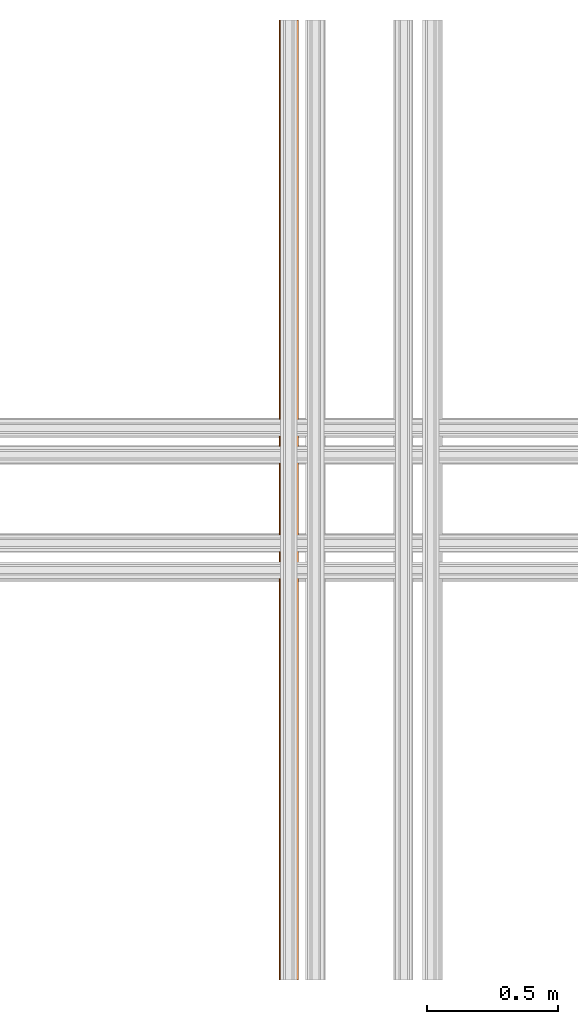
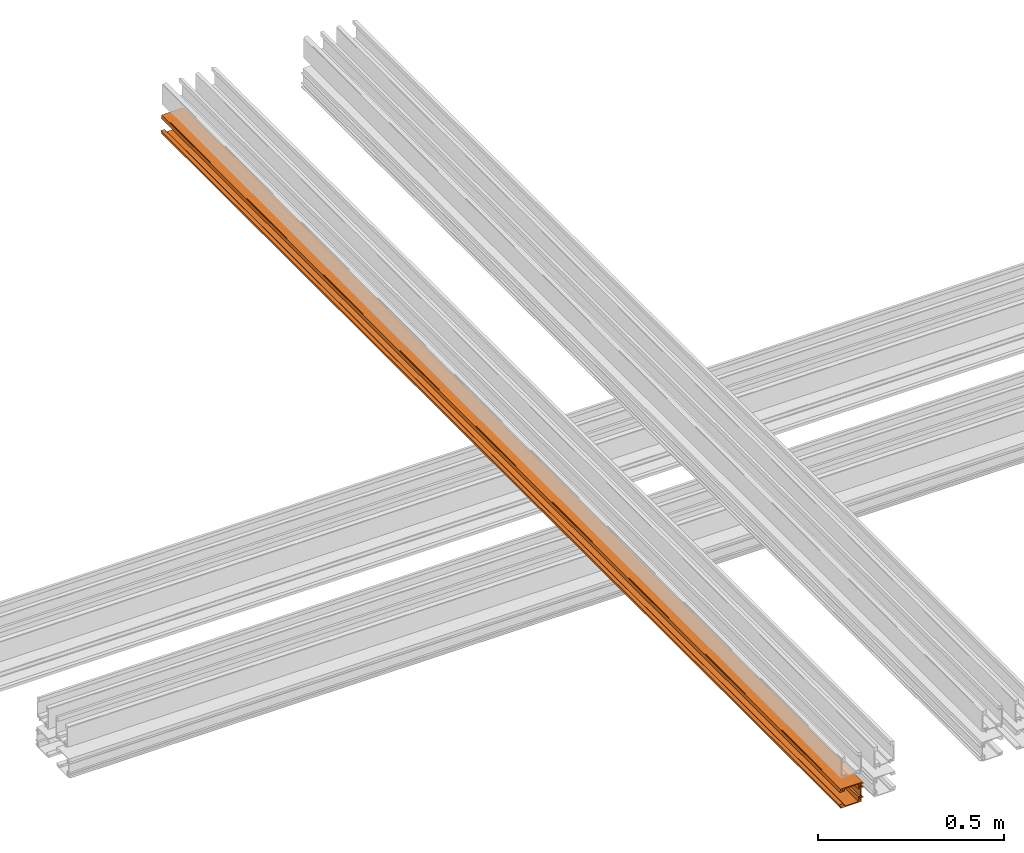
# One storey, part 4 of 4: 1 proxy.
"""IFC2X3 building model written with IfcOpenShell, lengths in feet."""

import ifcopenshell
import ifcopenshell.guid

model = None  # the IFC model being written
_history = None  # IfcOwnerHistory: only IFC2X3 demands one
_inside = {}  # id of a spatial element -> (the spatial element, [elements in it])
_under = {}  # id of a project, library or spatial element -> (it, [spatial elements below it])
_declared = {}  # id of a project -> (the project, [libraries it declares])
_typed = {}  # id of a type object -> (the type object, [elements of that type])
_made_of = {}  # id of a material, layer set ... -> (it, [elements and type objects made of it])


def new_model(schema):
    """Start an empty IFC model of exactly this schema.

    Asked for "IFC4X3", IfcOpenShell would pick the latest addendum, in which some entities
    have other attributes; the version numbers below select the first issue.
    IFC2X3 requires an IfcOwnerHistory on every rooted entity: one is made here for all.
    """
    global model, _history
    if schema == "IFC4X3":
        model = ifcopenshell.file(schema_version=(4, 3, 0, 0))
    else:
        model = ifcopenshell.file(schema=schema)
    _inside.clear()
    _under.clear()
    _declared.clear()
    _typed.clear()
    _made_of.clear()
    _history = None
    if model.schema == "IFC2X3":
        org = make("IfcOrganization", Name="unknown")
        user = make(
            "IfcPersonAndOrganization",
            ThePerson=make("IfcPerson", FamilyName="unknown"),
            TheOrganization=org,
        )
        app = make(
            "IfcApplication",
            ApplicationDeveloper=org,
            Version="unknown",
            ApplicationFullName="unknown",
            ApplicationIdentifier="unknown",
        )
        _history = make(
            "IfcOwnerHistory",
            OwningUser=user,
            OwningApplication=app,
            ChangeAction="ADDED",
            CreationDate=0,
        )
    return model


def make(cls, **values):
    """One entity of the class cls with the attributes given. An attribute that is None is left unset."""
    return model.create_entity(
        cls, **{name: value for name, value in values.items() if value is not None}
    )


def entity(cls, *values):
    """Any entity or typed value of the class cls, its attributes in the order of the schema. None: left unset."""
    e = model.create_entity(cls)
    for i, value in enumerate(values):
        if value is not None:
            e[i] = value
    return e


def rooted(cls, **values):
    """An entity with a GlobalId (a new one), such as an element, a storey or a relation."""
    return make(cls, GlobalId=ifcopenshell.guid.new(), OwnerHistory=_history, **values)


def si_unit(unit_type, name, prefix=None):
    """IfcSIUnit, for example si_unit("LENGTHUNIT", "METRE", prefix="MILLI")."""
    return make("IfcSIUnit", UnitType=unit_type, Prefix=prefix, Name=name)


def converted_unit(unit_type, name, factor, base, dimensions=None, offset=None):
    """IfcConversionBasedUnit, such as the inch: factor (a typed value) times the base unit."""
    return make(
        "IfcConversionBasedUnit"
        if offset is None
        else "IfcConversionBasedUnitWithOffset",
        ConversionOffset=offset,
        Dimensions=None
        if dimensions is None
        else entity("IfcDimensionalExponents", *dimensions),
        UnitType=unit_type,
        Name=name,
        ConversionFactor=make(
            "IfcMeasureWithUnit", ValueComponent=factor, UnitComponent=base
        ),
    )


def derived_unit(unit_type, elements):
    """IfcDerivedUnit: a product of units, each with its exponent."""
    return make(
        "IfcDerivedUnit",
        Elements=[
            make("IfcDerivedUnitElement", Unit=unit, Exponent=power)
            for unit, power in elements
        ],
        UnitType=unit_type,
    )


def assignment(units):
    """IfcUnitAssignment: the units of a project."""
    return None if units is None else make("IfcUnitAssignment", Units=units)


def point(xyz):
    """IfcCartesianPoint."""
    return None if xyz is None else make("IfcCartesianPoint", Coordinates=xyz)


def direction(xyz):
    """IfcDirection."""
    return None if xyz is None else make("IfcDirection", DirectionRatios=xyz)


def frame(location, z_axis=None, x_axis=None):
    """IfcAxis2Placement3D, a coordinate frame: its origin and axes. An axis left out is left unset."""
    return make(
        "IfcAxis2Placement3D",
        Location=point(location),
        Axis=direction(z_axis),
        RefDirection=direction(x_axis),
    )


def origin():
    """The frame at (0, 0, 0) with its axes left unset."""
    return frame((0.0, 0.0, 0.0))


def place(relative_to, where):
    """IfcLocalPlacement: puts the frame where relative to a parent placement (None: the world)."""
    return make(
        "IfcLocalPlacement", PlacementRelTo=relative_to, RelativePlacement=where
    )


def context(
    kind, dimensions, precision=None, world=None, true_north=None, identifier=None
):
    """IfcGeometricRepresentationContext, for example the 3D "Model" context."""
    return make(
        "IfcGeometricRepresentationContext",
        ContextIdentifier=identifier,
        ContextType=kind,
        CoordinateSpaceDimension=dimensions,
        Precision=precision,
        WorldCoordinateSystem=world,
        TrueNorth=true_north,
    )


def subcontext(parent, identifier, kind, view, scale=None):
    """IfcGeometricRepresentationSubContext, for example "Body" below "Model"."""
    return make(
        "IfcGeometricRepresentationSubContext",
        ContextIdentifier=identifier,
        ContextType=kind,
        ParentContext=parent,
        TargetScale=scale,
        TargetView=view,
    )


def project(units=None, contexts=None):
    """IfcProject with its units and contexts."""
    return rooted(
        "IfcProject",
        Name="project",
        RepresentationContexts=contexts,
        UnitsInContext=assignment(units),
    )


def spatial(cls, under=None, at=None, **own):
    """A site, building, storey or space (cls), placed at a placement, below another one or the project."""
    s = rooted(cls, ObjectPlacement=at, **own)
    if under is not None:
        _under.setdefault(under.id(), (under, []))[1].append(s)
    return s


def polyline(points):
    """IfcPolyline through the points."""
    return make("IfcPolyline", Points=[point(p) for p in points])


def outline(outer, holes=None, kind="AREA"):
    """IfcArbitraryClosedProfileDef: a profile drawn as a closed curve; with holes, ...WithVoids."""
    if holes is None:
        return make("IfcArbitraryClosedProfileDef", ProfileType=kind, OuterCurve=outer)
    return make(
        "IfcArbitraryProfileDefWithVoids",
        ProfileType=kind,
        OuterCurve=outer,
        InnerCurves=holes,
    )


def extrude(swept, where, along, depth):
    """IfcExtrudedAreaSolid: the profile swept, set in the frame where, extruded along a direction by depth."""
    return make(
        "IfcExtrudedAreaSolid",
        SweptArea=swept,
        Position=where,
        ExtrudedDirection=direction(along),
        Depth=depth,
    )


def shape(context_of_items, identifier, shape_type, items):
    """IfcShapeRepresentation: the items that make up one representation, for example the "Body"."""
    return make(
        "IfcShapeRepresentation",
        ContextOfItems=context_of_items,
        RepresentationIdentifier=identifier,
        RepresentationType=shape_type,
        Items=items,
    )


def source(mapping_origin, context_of_items, identifier, shape_type, items):
    """IfcRepresentationMap: a shape defined once, which mapped items show again and again."""
    return make(
        "IfcRepresentationMap",
        MappingOrigin=mapping_origin,
        MappedRepresentation=shape(context_of_items, identifier, shape_type, items),
    )


def transform(
    local_origin,
    x_axis=None,
    y_axis=None,
    z_axis=None,
    scale=None,
    scale2=None,
    scale3=None,
    uniform=True,
):
    """IfcCartesianTransformationOperator3D, or its non-uniform kind. x_axis, y_axis, z_axis: its Axis1, 2, 3."""
    if uniform:
        return make(
            "IfcCartesianTransformationOperator3D",
            Axis1=direction(x_axis),
            Axis2=direction(y_axis),
            LocalOrigin=point(local_origin),
            Scale=scale,
            Axis3=direction(z_axis),
        )
    return make(
        "IfcCartesianTransformationOperator3DnonUniform",
        Axis1=direction(x_axis),
        Axis2=direction(y_axis),
        LocalOrigin=point(local_origin),
        Scale=scale,
        Axis3=direction(z_axis),
        Scale2=scale2,
        Scale3=scale3,
    )


def mapped(mapping_source, mapping_target):
    """IfcMappedItem: shows the shape of a source again, moved by a transform."""
    return make(
        "IfcMappedItem", MappingSource=mapping_source, MappingTarget=mapping_target
    )


def material(Name=None, Category=None):
    """IfcMaterial."""
    return make("IfcMaterial", Name=Name, Category=Category)


def made_of(thing, what):
    """Note that an element or type object is made of a material, layer set ...; save() writes the relation."""
    if what is not None:
        _made_of.setdefault(what.id(), (what, []))[1].append(thing)
    return thing


def type_object(cls, material=None, **own):
    """A type object (cls), such as IfcWallType, which elements share."""
    return made_of(rooted(cls, **own), material)


def type_shapes(of_type, sources):
    """Give a type object the sources (RepresentationMaps) that its elements show as mapped items."""
    of_type.RepresentationMaps = sources


def element(
    cls,
    number,
    at=None,
    inside=None,
    cuts=None,
    type_object=None,
    material=None,
    context=None,
    identifier="Body",
    shape_type=None,
    held_by="IfcProductDefinitionShape",
    body=None,
    shapes=None,
    **own,
):
    """One element of the class cls, such as IfcWall. Its Tag is "e" and its number.

    at: its placement. inside: the storey or other place that contains it. cuts: it is an
    opening in that element (IfcRelVoidsElement). A single representation is given by context,
    identifier, shape_type and body (its items); several are given by shapes. held_by: the class
    of the entity that holds the representations. save() writes the other relations.
    """
    e = rooted(cls, Tag="e%d" % number, ObjectPlacement=at, **own)
    if body is not None:
        shapes = [shape(context, identifier, shape_type, body)]
    if shapes is not None:
        e.Representation = make(held_by, Representations=shapes)
    if inside is not None:
        _inside.setdefault(inside.id(), (inside, []))[1].append(e)
    if cuts is not None:
        rooted(
            "IfcRelVoidsElement", RelatingBuildingElement=cuts, RelatedOpeningElement=e
        )
    if type_object is not None:
        _typed.setdefault(type_object.id(), (type_object, []))[1].append(e)
    return made_of(e, material)


def aggregate(whole, parts):
    """IfcRelAggregates: a whole, such as a stair, and the parts it consists of."""
    return rooted("IfcRelAggregates", RelatingObject=whole, RelatedObjects=parts)


def save(model, path):
    """Write the relations noted so far, then the file.

    IfcRelAggregates (storeys below a building ...), IfcRelContainedInSpatialStructure (elements
    in a storey), IfcRelDefinesByType, IfcRelAssociatesMaterial and IfcRelDeclares: one each for
    every whole, place, type object, material and project.
    """
    for whole, parts in _under.values():
        aggregate(whole, parts)
    for where, things in _inside.values():
        rooted(
            "IfcRelContainedInSpatialStructure",
            RelatedElements=things,
            RelatingStructure=where,
        )
    for kind, things in _typed.values():
        rooted("IfcRelDefinesByType", RelatedObjects=things, RelatingType=kind)
    for what, things in _made_of.values():
        rooted("IfcRelAssociatesMaterial", RelatedObjects=things, RelatingMaterial=what)
    for by, libraries in _declared.values():
        rooted("IfcRelDeclares", RelatingContext=by, RelatedDefinitions=libraries)
    model.write(path)


model = new_model("IFC2X3")

# Units and contexts
model_context = context("Model", 3, precision=0.0001, world=origin(), true_north=direction((6.12303176911189e-17, 1.0)))
body_context = subcontext(model_context, "Body", "Model", "MODEL_VIEW")
ifc_project = project(units=[converted_unit("LENGTHUNIT", "FOOT", entity("IfcRatioMeasure", 0.3048), si_unit("LENGTHUNIT", "METRE"), dimensions=[1, 0, 0, 0, 0, 0, 0]), converted_unit("AREAUNIT", "SQUARE FOOT", entity("IfcRatioMeasure", 0.09290304), si_unit("AREAUNIT", "SQUARE_METRE"), dimensions=[2, 0, 0, 0, 0, 0, 0]), converted_unit("VOLUMEUNIT", "CUBIC FOOT", entity("IfcRatioMeasure", 0.028316846592), si_unit("VOLUMEUNIT", "CUBIC_METRE"), dimensions=[3, 0, 0, 0, 0, 0, 0]), converted_unit("PLANEANGLEUNIT", "DEGREE", entity("IfcRatioMeasure", 0.0174532925199433), si_unit("PLANEANGLEUNIT", "RADIAN"), dimensions=[0, 0, 0, 0, 0, 0, 0]), si_unit("MASSUNIT", "GRAM", prefix="KILO"), derived_unit("MASSDENSITYUNIT", [(si_unit("MASSUNIT", "GRAM", prefix="KILO"), 1), (si_unit("LENGTHUNIT", "METRE"), -3)]), si_unit("TIMEUNIT", "SECOND"), si_unit("FREQUENCYUNIT", "HERTZ"), si_unit("THERMODYNAMICTEMPERATUREUNIT", "DEGREE_CELSIUS"), derived_unit("THERMALTRANSMITTANCEUNIT", [(si_unit("MASSUNIT", "GRAM", prefix="KILO"), 1), (si_unit("THERMODYNAMICTEMPERATUREUNIT", "KELVIN"), -1), (si_unit("TIMEUNIT", "SECOND"), -3)]), derived_unit("VOLUMETRICFLOWRATEUNIT", [(si_unit("LENGTHUNIT", "METRE"), 3), (si_unit("TIMEUNIT", "SECOND"), -1)]), si_unit("ELECTRICCURRENTUNIT", "AMPERE"), si_unit("ELECTRICVOLTAGEUNIT", "VOLT"), si_unit("POWERUNIT", "WATT"), si_unit("FORCEUNIT", "NEWTON"), si_unit("ILLUMINANCEUNIT", "LUX"), si_unit("LUMINOUSFLUXUNIT", "LUMEN"), si_unit("LUMINOUSINTENSITYUNIT", "CANDELA"), derived_unit("USERDEFINED", [(si_unit("MASSUNIT", "GRAM", prefix="KILO"), -1), (si_unit("LENGTHUNIT", "METRE"), -2), (si_unit("TIMEUNIT", "SECOND"), 3), (si_unit("LUMINOUSFLUXUNIT", "LUMEN"), 1)]), derived_unit("LINEARVELOCITYUNIT", [(si_unit("LENGTHUNIT", "METRE"), 1), (si_unit("TIMEUNIT", "SECOND"), -1)]), si_unit("PRESSUREUNIT", "PASCAL"), derived_unit("USERDEFINED", [(si_unit("LENGTHUNIT", "METRE"), -2), (si_unit("MASSUNIT", "GRAM", prefix="KILO"), 1), (si_unit("TIMEUNIT", "SECOND"), -2)])], contexts=[model_context])

# Site, building, storey
site_placement = place(None, origin())
site = spatial("IfcSite", under=ifc_project, at=site_placement, CompositionType="ELEMENT")
building_placement = place(site_placement, origin())
building = spatial("IfcBuilding", under=site, at=building_placement, CompositionType="ELEMENT")
storey_placement = place(building_placement, origin())
storey = spatial("IfcBuildingStorey", under=building, at=storey_placement, Name="Level 1", CompositionType="ELEMENT", Elevation=0.0)

# Proxy
ifc_material = material(Name="THERMAL BROKEN ALUMINUM STOREFRONT FOR POLYCARBONATE")
building_element_proxy_type = type_object("IfcBuildingElementProxyType", Name="Generic Models 2", PredefinedType="NOTDEFINED", material=ifc_material)
shared_shape = source(origin(), body_context, "Body", "SweptSolid", [
    extrude(outline(polyline([(-0.0104080468283571, -0.0212270141141865), (0.0284072982254619, -0.0212270141141865), (0.0185964943745741, 0.0155635003266429), (-0.00515653981588791, 0.0270511459549447), (-0.00897742822638776, 0.0260322423788114), (-0.00514872339515044, 0.0116745992616716), (-0.0064740101252062, -0.00299045881680828), (-0.00136839731267846, -0.00250162354759874), (0.00181539143775597, -0.0144408313617281), (-0.0112860383341235, -0.0179345459675626), (-0.0104080468283571, -0.0212270141141865)])), frame((-15.0474625405981, 0.579193333610883, -0.488678668263244), z_axis=(1.0, 0.0, 0.0), x_axis=(0.0, 0.257662650560332, 0.966234939601246)), (0.0, 0.0, 1.0), 12.0),
    extrude(outline(polyline([(0.0679666623619383, 0.000632417738883341), (0.0710872151823902, 0.000632417738883342), (0.072579012039196, 0.00314266314992776), (0.0702488184526765, 0.00635088523716542), (0.0700096732994305, 0.0109637083615181), (0.0775858665392125, 0.0113564851588299), (0.0770520929428696, 0.0216523375102529), (-0.134304272308872, 0.0106948719853311), (-0.133377721915217, -0.00717717360587389), (-0.123081869563794, -0.00664340000953091), (-0.122412698736183, -0.000765203056202739), (-0.106181130798194, -0.00576720561553113), (-0.0921943125095252, -0.00504207922050203), (-0.092587089306837, 0.00253411401928001), (0.0533031958989612, 0.0100975851674497), (0.0553677918848116, -0.0297259946823082), (0.0598635549062836, -0.029492918341043), (0.0628161856570253, 0.00318899968962246), (0.0662590259738255, 0.00336748877384854), (0.0679666623619383, 0.000632417738883341)])), frame((-15.0474625405981, 0.459395210905167, -0.491860847636116), z_axis=(1.0, 0.0, 0.0), x_axis=(0.0, -0.99865882581399, 0.05177402460523)), (0.0, 0.0, 1.0), 12.0),
    extrude(outline(polyline([(-0.0730229494703184, 0.10703462932325), (-0.0580447359626436, 0.10703462932325), (-0.0580447359626436, 0.113745897781071), (-0.0623242255363625, 0.118025006955696), (-0.0623242255363624, 0.112092207910207), (-0.0671872818698961, 0.112092207910207), (-0.070447847400705, 0.11773967307098), (-0.070447847400705, 0.125224643652343), (-0.067542920423974, 0.131454279657517), (-0.0623242255363624, 0.131454279657517), (-0.0623242255363624, 0.124783598829804), (-0.0580447359626436, 0.125514243391176), (-0.0580447359626435, 0.142048634925557), (-0.0813874063643329, 0.140085232742292), (-0.0813874063643329, -0.0647285203812247), (-0.0697160711634882, -0.0647285203812247), (-0.0697160711634882, -0.0853478792356713), (-0.0631023145498278, -0.0853478792356712), (-0.0631023145498279, -0.0647285203809973), (-0.027310219934056, -0.0647285203809974), (-0.0273102199340559, -0.0853478792356713), (-0.0206964633203955, -0.0853478792356713), (-0.0206964633203956, -0.0647285203809974), (0.0812331974328895, -0.0647285203809974), (0.0812331974328896, -0.0853478792356713), (0.08784695404655, -0.0853478792356713), (0.0878469540465499, -0.0647285203812247), (0.116052680781773, -0.0647285203812247), (0.116052680781773, -0.0602545085540827), (0.113329369234955, -0.0585038082739666), (0.110217013181205, -0.0606435530609291), (0.0878469540467773, -0.0606435530609291), (0.0835674644730585, -0.0563640634872103), (0.0713125625121716, -0.0563640634872103), (0.0713125625121717, -0.0388570606861707), (0.115469114021731, -0.0388570606861707), (0.115469114021731, -0.0337994820992139), (0.0646988058985113, -0.0337994820992139), (0.0646988058985112, -0.0563640634872103), (-0.0203074188135492, -0.0563640634872103), (-0.0203074188135491, -0.0337994820992139), (-0.0730229494703184, -0.0337994820992138), (-0.0730229494703184, 0.10703462932325)]), holes=[polyline([(-0.0710777269369959, -0.057725719260718), (-0.0710777269369958, -0.0388570606861707), (-0.0273102199340559, -0.0388570606861707), (-0.027310219934056, -0.057725719260718), (-0.0710777269369959, -0.057725719260718)])]), frame((-15.0474625405981, 0.4470265612332, -0.382548921665172), z_axis=(1.0, 0.0, 0.0), x_axis=(0.0, 0.0, -1.0)), (0.0, 0.0, 1.0), 12.0),
    extrude(outline(polyline([(-0.0218274236802372, -0.025076209688489), (0.0116463755794956, -0.025076209688489), (0.0131456738465899, -0.0183468011873072), (-0.00944342914962783, -0.0152716423802922), (-0.00556193395869956, 0.00214995231397101), (0.000832544625431189, 0.00182921635388828), (-0.000621696809064723, -0.00469796031725753), (0.00265859892029526, -0.0054288034072145), (0.00663400184610042, -0.000259219921661603), (0.00811823413249314, 0.00640256685218482), (0.00642611525779212, 0.0117890219260673), (0.00293818751194467, 0.012566124998972), (0.00132974729935316, 0.00534684683544), (-0.00324578604653784, 0.0125456859662898), (-0.00165600184121952, 0.0196812290274093), (-0.011373207534109, 0.0218462023164866), (-0.0218274236802372, -0.025076209688489)])), frame((-15.0474625405981, 0.572911282830073, -0.319614529867372), z_axis=(1.0, 0.0, 0.0), x_axis=(0.0, -0.217465908950321, 0.976067916921979)), (0.0, 0.0, 1.0), 12.0),
])
type_shapes(building_element_proxy_type, [shared_shape])
proxy_placement = place(storey_placement, frame((5.58478441699744, 9.81950034970276, 1.46782818196766), z_axis=(0.0, 0.0, 1.0), x_axis=(0.0, 1.0, 0.0)))
element("IfcBuildingElementProxy", 1, at=proxy_placement, inside=storey, type_object=building_element_proxy_type, material=ifc_material, Name="Generic Models 16:Generic Models 2", ObjectType="Generic Models 16:Generic Models 2", context=body_context, shape_type="MappedRepresentation", body=[
    mapped(shared_shape, transform((0.0, 0.0, 0.0), scale=1.0)),
])

save(model, "model.ifc")
